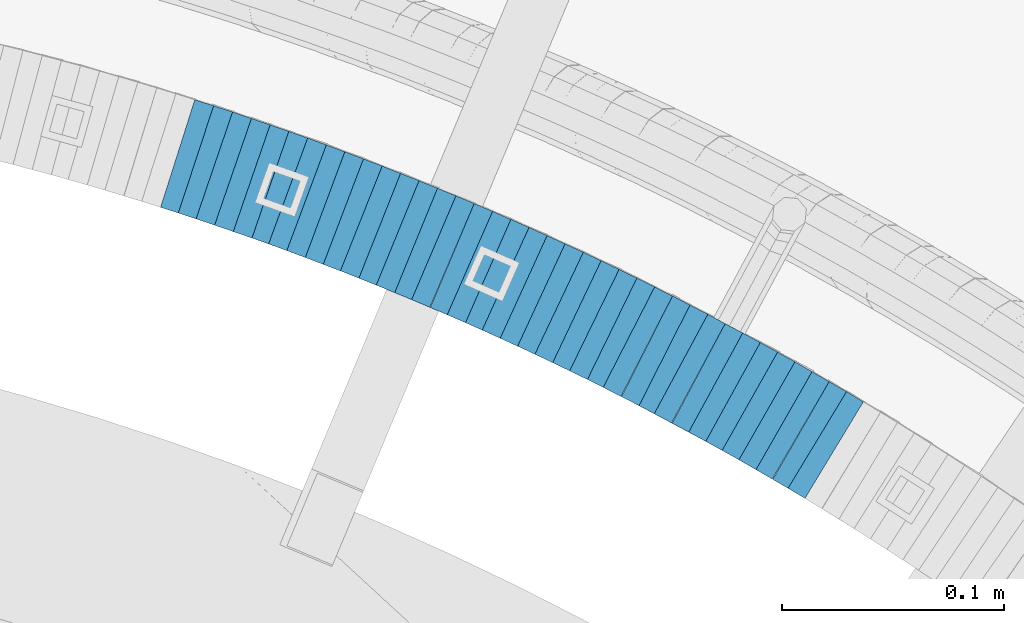
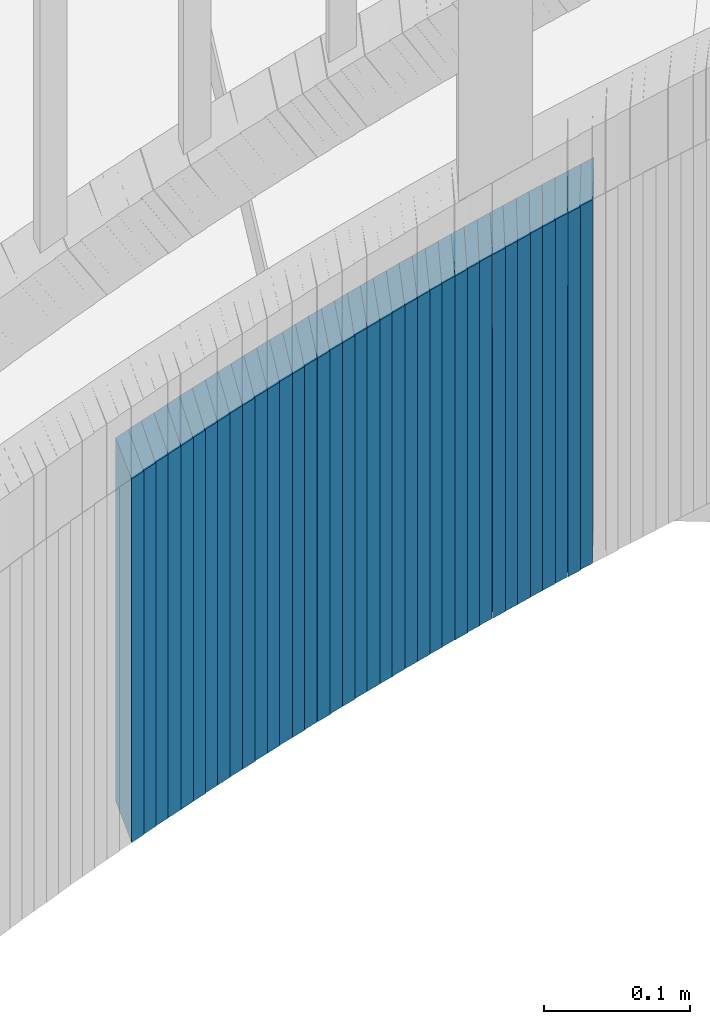
# One storey, part 900 of 975: 37 plates.
"""IFC2X3 building model written with IfcOpenShell, lengths in millimetres."""

from ifc_helpers import new_model, si_unit, frame, origin_with_axes, place, context, subcontext, project, spatial, faceted_brep, material, type_object, element, save


model = new_model("IFC2X3")

# Units and contexts
model_context = context("Model", 3, precision=1e-05, world=origin_with_axes())
body_context = subcontext(model_context, "Body", "Model", "MODEL_VIEW")
ifc_project = project(units=[si_unit("LENGTHUNIT", "METRE", prefix="MILLI"), si_unit("AREAUNIT", "SQUARE_METRE"), si_unit("VOLUMEUNIT", "CUBIC_METRE"), si_unit("MASSUNIT", "GRAM", prefix="KILO"), si_unit("TIMEUNIT", "SECOND"), si_unit("PLANEANGLEUNIT", "RADIAN"), si_unit("SOLIDANGLEUNIT", "STERADIAN"), si_unit("THERMODYNAMICTEMPERATUREUNIT", "DEGREE_CELSIUS"), si_unit("LUMINOUSINTENSITYUNIT", "LUMEN")], contexts=[model_context])

# Site, building, storey
site_placement = place(None, origin_with_axes())
site = spatial("IfcSite", under=ifc_project, at=site_placement, CompositionType="ELEMENT")
building_placement = place(site_placement, origin_with_axes())
building = spatial("IfcBuilding", under=site, at=building_placement, Name="Undefined", CompositionType="ELEMENT")
storey_placement = place(building_placement, origin_with_axes())
storey = spatial("IfcBuildingStorey", under=building, at=storey_placement, Name="Undefined", CompositionType="ELEMENT", Elevation=0.0)

# Plates
ifc_material = material(Name="STEEL/A36")
plate_type = type_object("IfcPlateType", PredefinedType="NOTDEFINED")
plate_1_placement = place(storey_placement, frame((35445.7233740087, 4606.22785102117, 1554.3000000007), z_axis=(0.855500079109598, -0.517802679254822, 1.05275375972269e-10), x_axis=(0.0, 0.0, -1.0)))
element("IfcPlate", 1, at=plate_1_placement, inside=storey, type_object=plate_type, material=ifc_material, Name="WALL", context=body_context, shape_type="Brep", body=[
    faceted_brep([(0.0, -25.3999999999724, -1.81898940354586e-11), (-5.69999980926514, -25.4000000000669, 8.8814411163039), (-5.69999980926514, 25.400000000096, 8.88144111637848), (0.0, 25.3999999999869, 1.45519152283669e-11), (299.100006103516, -25.4000000000669, 8.8814411163039), (299.100006103516, 25.400000000096, 8.88144111637848), (304.799987792969, -25.3999999999724, -1.81898940354586e-11), (304.799987792969, 25.3999999999869, 1.45519152283669e-11)], [[[0, 1, 2, 3]], [[1, 4, 5, 2]], [[4, 6, 7, 5]], [[6, 0, 3, 7]], [[5, 7, 3, 2]], [[6, 4, 1, 0]]]),
])
plate_2_placement = place(storey_placement, frame((35438.3826117312, 4610.45643915297, 1548.5000000007), z_axis=(0.866185585981234, -0.499722453606346, 3.44320142176002e-10), x_axis=(0.0, 0.0, -1.0)))
element("IfcPlate", 2, at=plate_2_placement, inside=storey, type_object=plate_type, material=ifc_material, Name="WALL", context=body_context, shape_type="Brep", body=[
    faceted_brep([(0.0, -25.3999999999724, -1.81898940354586e-11), (-5.80000019073486, -25.3999999999578, 8.99610996247975), (-5.80000019073486, 25.3999999999796, 8.99610996245065), (0.0, 25.3999999999869, 1.45519152283669e-11), (299.0, -25.3999999999578, 8.99610996247975), (299.0, 25.3999999999796, 8.99610996245065), (304.799987792969, -25.3999999999724, -1.81898940354586e-11), (304.799987792969, 25.3999999999869, 1.45519152283669e-11)], [[[0, 1, 2, 3]], [[1, 4, 5, 2]], [[4, 6, 7, 5]], [[6, 0, 3, 7]], [[5, 7, 3, 2]], [[6, 4, 1, 0]]]),
])
plate_3_placement = place(storey_placement, frame((35430.5595343687, 4615.02790564917, 1542.80000000069), z_axis=(0.863371944049593, -0.504568019426546, 2.19373305299087e-10), x_axis=(0.0, 0.0, -1.0)))
element("IfcPlate", 3, at=plate_3_placement, inside=storey, type_object=plate_type, material=ifc_material, Name="WALL", context=body_context, shape_type="Brep", body=[
    faceted_brep([(0.0, -25.3999999999724, -1.81898940354586e-11), (-5.69999980926514, -25.3999999999724, 8.91964149478372), (-5.69999980926514, 25.400000000016, 8.9196414947528), (0.0, 25.3999999999869, 1.45519152283669e-11), (299.100006103516, -25.3999999999724, 8.91964149478372), (299.100006103516, 25.400000000016, 8.9196414947528), (304.799987792969, -25.3999999999724, -1.81898940354586e-11), (304.799987792969, 25.3999999999869, 1.45519152283669e-11)], [[[0, 1, 2, 3]], [[1, 4, 5, 2]], [[4, 6, 7, 5]], [[6, 0, 3, 7]], [[5, 7, 3, 2]], [[6, 4, 1, 0]]]),
])
plate_4_placement = place(storey_placement, frame((35423.0736330301, 4619.30417721957, 1537.10000000069), z_axis=(0.868243142247536, -0.49613893814145, 0.0), x_axis=(0.0, 0.0, -1.0)))
element("IfcPlate", 4, at=plate_4_placement, inside=storey, type_object=plate_type, material=ifc_material, Name="WALL", context=body_context, shape_type="Brep", body=[
    faceted_brep([(0.0, -25.3999999999724, -1.81898940354586e-11), (-5.69999980926514, -25.4000000000378, 8.86848354337781), (-5.69999980926514, 25.4000000000451, 8.86848354342146), (0.0, 25.3999999999869, 1.45519152283669e-11), (299.100006103516, -25.4000000000378, 8.86848354337781), (299.100006103516, 25.4000000000451, 8.86848354342146), (304.799987792969, -25.3999999999724, -1.81898940354586e-11), (304.799987792969, 25.3999999999869, 1.45519152283669e-11)], [[[0, 1, 2, 3]], [[1, 4, 5, 2]], [[4, 6, 7, 5]], [[6, 0, 3, 7]], [[5, 7, 3, 2]], [[6, 4, 1, 0]]]),
])
plate_5_placement = place(storey_placement, frame((35415.3960039102, 4623.63469995071, 1531.40000000068), z_axis=(0.870978467909721, -0.491321186636232, -1.73427451954922e-10), x_axis=(0.0, 0.0, -1.0)))
element("IfcPlate", 5, at=plate_5_placement, inside=storey, type_object=plate_type, material=ifc_material, Name="WALL", context=body_context, shape_type="Brep", body=[
    faceted_brep([(0.0, -25.3999999999724, -1.81898940354586e-11), (-5.69999980926514, -25.4000000000087, 8.9643735885511), (-5.69999980926514, 25.4000000000669, 8.96437358860567), (0.0, 25.3999999999869, 1.45519152283669e-11), (299.100006103516, -25.4000000000087, 8.9643735885511), (299.100006103516, 25.4000000000669, 8.96437358860567), (304.799987792969, -25.3999999999724, -1.81898940354586e-11), (304.799987792969, 25.3999999999869, 1.45519152283669e-11)], [[[0, 1, 2, 3]], [[1, 4, 5, 2]], [[4, 6, 7, 5]], [[6, 0, 3, 7]], [[5, 7, 3, 2]], [[6, 4, 1, 0]]]),
])
plate_6_placement = place(storey_placement, frame((35407.8129371245, 4627.81372175488, 1525.60000000066), z_axis=(0.875741388860291, -0.482780508965563, 2.42835085373372e-11), x_axis=(0.0, 0.0, -1.0)))
element("IfcPlate", 6, at=plate_6_placement, inside=storey, type_object=plate_type, material=ifc_material, Name="WALL", context=body_context, shape_type="Brep", body=[
    faceted_brep([(0.0, -25.3999999999724, -1.81898940354586e-11), (-5.80000019073486, -25.399999999976, 8.91066741944087), (-5.80000019073486, 25.4000000000051, 8.91066741945178), (0.0, 25.3999999999869, 1.45519152283669e-11), (299.0, -25.399999999976, 8.91066741944087), (299.0, 25.4000000000051, 8.91066741945178), (304.799987792969, -25.3999999999724, -1.81898940354586e-11), (304.799987792969, 25.3999999999869, 1.45519152283669e-11)], [[[0, 1, 2, 3]], [[1, 4, 5, 2]], [[4, 6, 7, 5]], [[6, 0, 3, 7]], [[5, 7, 3, 2]], [[6, 4, 1, 0]]]),
])
plate_7_placement = place(storey_placement, frame((35400.0325084612, 4632.04822203603, 1519.90000000066), z_axis=(0.878320117971443, -0.478072975984453, 0.0), x_axis=(0.0, 0.0, -1.0)))
element("IfcPlate", 7, at=plate_7_placement, inside=storey, type_object=plate_type, material=ifc_material, Name="WALL", context=body_context, shape_type="Brep", body=[
    faceted_brep([(0.0, -25.3999999999724, -1.81898940354586e-11), (-5.69999980926514, -25.3999999999724, 8.9872131347729), (-5.69999980926514, 25.3999999999833, 8.98721313475835), (0.0, 25.3999999999869, 1.45519152283669e-11), (299.100006103516, -25.3999999999724, 8.9872131347729), (299.100006103516, 25.3999999999833, 8.98721313475835), (304.799987792969, -25.3999999999724, -1.81898940354586e-11), (304.799987792969, 25.3999999999869, 1.45519152283669e-11)], [[[0, 1, 2, 3]], [[1, 4, 5, 2]], [[4, 6, 7, 5]], [[6, 0, 3, 7]], [[5, 7, 3, 2]], [[6, 4, 1, 0]]]),
])
plate_8_placement = place(storey_placement, frame((35392.3521009664, 4636.13009049923, 1514.20000000066), z_axis=(0.882970965834168, -0.469427601972739, 3.48595676769037e-11), x_axis=(0.0, 0.0, -1.0)))
element("IfcPlate", 8, at=plate_8_placement, inside=storey, type_object=plate_type, material=ifc_material, Name="WALL", context=body_context, shape_type="Brep", body=[
    faceted_brep([(0.0, -25.3999999999724, -1.81898940354586e-11), (-5.69999980926514, -25.4000000000451, 8.94986057279493), (-5.69999980926514, 25.3999999999942, 8.94986057280948), (0.0, 25.3999999999869, 1.45519152283669e-11), (299.100006103516, -25.4000000000451, 8.94986057279493), (299.100006103516, 25.3999999999942, 8.94986057280948), (304.799987792969, -25.3999999999724, -1.81898940354586e-11), (304.799987792969, 25.3999999999869, 1.45519152283669e-11)], [[[0, 1, 2, 3]], [[1, 4, 5, 2]], [[4, 6, 7, 5]], [[6, 0, 3, 7]], [[5, 7, 3, 2]], [[6, 4, 1, 0]]]),
])
plate_9_placement = place(storey_placement, frame((35384.4334265492, 4640.39358709318, 1508.40000000065), z_axis=(0.880471099954286, -0.474099822975383, 0.0), x_axis=(0.0, 0.0, -1.0)))
element("IfcPlate", 9, at=plate_9_placement, inside=storey, type_object=plate_type, material=ifc_material, Name="WALL", context=body_context, shape_type="Brep", body=[
    faceted_brep([(0.0, -25.3999999999724, -1.81898940354586e-11), (-5.80000019073486, -25.3999999999905, 8.8617153167761), (-5.80000019073486, 25.4000000000524, 8.86171531681975), (0.0, 25.3999999999869, 1.45519152283669e-11), (299.0, -25.3999999999905, 8.8617153167761), (299.0, 25.4000000000524, 8.86171531681975), (304.799987792969, -25.3999999999724, -1.81898940354586e-11), (304.799987792969, 25.3999999999869, 1.45519152283669e-11)], [[[0, 1, 2, 3]], [[1, 4, 5, 2]], [[4, 6, 7, 5]], [[6, 0, 3, 7]], [[5, 7, 3, 2]], [[6, 4, 1, 0]]]),
])
plate_10_placement = place(storey_placement, frame((35376.668781017, 4644.46844629938, 1502.70000000065), z_axis=(0.8853979028468, -0.464833898973051, 2.98718987323809e-11), x_axis=(0.0, 0.0, -1.0)))
element("IfcPlate", 10, at=plate_10_placement, inside=storey, type_object=plate_type, material=ifc_material, Name="WALL", context=body_context, shape_type="Brep", body=[
    faceted_brep([(0.0, -25.3999999999724, -1.81898940354586e-11), (-5.69999980926514, -25.3999999999614, 9.03548526772647), (-5.69999980926514, 25.3999999999869, 9.03548526759187), (0.0, 25.3999999999869, 1.45519152283669e-11), (299.100006103516, -25.3999999999614, 9.03548526772647), (299.100006103516, 25.3999999999869, 9.03548526759187), (304.799987792969, -25.3999999999724, -1.81898940354586e-11), (304.799987792969, 25.3999999999869, 1.45519152283669e-11)], [[[0, 1, 2, 3]], [[1, 4, 5, 2]], [[4, 6, 7, 5]], [[6, 0, 3, 7]], [[5, 7, 3, 2]], [[6, 4, 1, 0]]]),
])
plate_11_placement = place(storey_placement, frame((35369.1017434079, 4648.29676121252, 1497.00000000065), z_axis=(0.892157158245305, -0.451725143191812, 3.88258740713355e-11), x_axis=(0.0, 0.0, -1.0)))
element("IfcPlate", 11, at=plate_11_placement, inside=storey, type_object=plate_type, material=ifc_material, Name="WALL", context=body_context, shape_type="Brep", body=[
    faceted_brep([(0.0, -25.3999999999724, -1.81898940354586e-11), (-5.69999980926514, -25.4000000000669, 8.85494232174278), (-5.69999980926514, 25.4000000000742, 8.85494232181918), (0.0, 25.3999999999869, 1.45519152283669e-11), (299.100006103516, -25.4000000000669, 8.85494232174278), (299.100006103516, 25.4000000000742, 8.85494232181918), (304.799987792969, -25.3999999999724, -1.81898940354586e-11), (304.799987792969, 25.3999999999869, 1.45519152283669e-11)], [[[0, 1, 2, 3]], [[1, 4, 5, 2]], [[4, 6, 7, 5]], [[6, 0, 3, 7]], [[5, 7, 3, 2]], [[6, 4, 1, 0]]]),
])
plate_12_placement = place(storey_placement, frame((35360.990855953, 4652.45324846724, 1491.20000000064), z_axis=(0.88993325058996, -0.456090790845844, 3.15944816975389e-11), x_axis=(0.0, 0.0, -1.0)))
element("IfcPlate", 12, at=plate_12_placement, inside=storey, type_object=plate_type, material=ifc_material, Name="WALL", context=body_context, shape_type="Brep", body=[
    faceted_brep([(0.0, -25.3999999999724, -1.81898940354586e-11), (-5.80000019073486, -25.3999999999796, 8.98721313478018), (-5.80000019073486, 25.399999999936, 8.98721313473106), (0.0, 25.3999999999869, 1.45519152283669e-11), (299.0, -25.3999999999796, 8.98721313478018), (299.0, 25.399999999936, 8.98721313473106), (304.799987792969, -25.3999999999724, -1.81898940354586e-11), (304.799987792969, 25.3999999999869, 1.45519152283669e-11)], [[[0, 1, 2, 3]], [[1, 4, 5, 2]], [[4, 6, 7, 5]], [[6, 0, 3, 7]], [[5, 7, 3, 2]], [[6, 4, 1, 0]]]),
])
plate_13_placement = place(storey_placement, frame((35353.2163367046, 4656.33910238603, 1485.50000000063), z_axis=(0.894427190945564, -0.447213595608663, -1.9893241187674e-10), x_axis=(0.0, 0.0, -1.0)))
element("IfcPlate", 13, at=plate_13_placement, inside=storey, type_object=plate_type, material=ifc_material, Name="WALL", context=body_context, shape_type="Brep", body=[
    faceted_brep([(0.0, -25.3999999999724, -1.81898940354586e-11), (-5.69999980926514, -25.4000000000415, 8.93756103511259), (-5.69999980926514, 25.4000000000815, 8.93756103522537), (0.0, 25.3999999999869, 1.45519152283669e-11), (299.100006103516, -25.4000000000415, 8.93756103511259), (299.100006103516, 25.4000000000815, 8.93756103522537), (304.799987792969, -25.3999999999724, -1.81898940354586e-11), (304.799987792969, 25.3999999999869, 1.45519152283669e-11)], [[[0, 1, 2, 3]], [[1, 4, 5, 2]], [[4, 6, 7, 5]], [[6, 0, 3, 7]], [[5, 7, 3, 2]], [[6, 4, 1, 0]]]),
])
plate_14_placement = place(storey_placement, frame((35345.4452249515, 4660.12609235878, 1479.80000000063), z_axis=(0.898876404474688, -0.43820224723141, 0.0), x_axis=(0.0, 0.0, -1.0)))
element("IfcPlate", 14, at=plate_14_placement, inside=storey, type_object=plate_type, material=ifc_material, Name="WALL", context=body_context, shape_type="Brep", body=[
    faceted_brep([(0.0, -25.3999999999724, -1.81898940354586e-11), (-5.69999980926514, -25.3999999999724, 8.90224647524519), (-5.69999980926514, 25.3999999999542, 8.90224647519426), (0.0, 25.3999999999869, 1.45519152283669e-11), (299.100006103516, -25.3999999999724, 8.90224647524519), (299.100006103516, 25.3999999999542, 8.90224647519426), (304.799987792969, -25.3999999999724, -1.81898940354586e-11), (304.799987792969, 25.3999999999869, 1.45519152283669e-11)], [[[0, 1, 2, 3]], [[1, 4, 5, 2]], [[4, 6, 7, 5]], [[6, 0, 3, 7]], [[5, 7, 3, 2]], [[6, 4, 1, 0]]]),
])
plate_15_placement = place(storey_placement, frame((35337.4566453103, 4663.97211062152, 1474.10000000063), z_axis=(0.901001669715669, -0.433815618863102, 0.0), x_axis=(0.0, 0.0, -1.0)))
element("IfcPlate", 15, at=plate_15_placement, inside=storey, type_object=plate_type, material=ifc_material, Name="WALL", context=body_context, shape_type="Brep", body=[
    faceted_brep([(0.0, -25.3999999999724, -1.81898940354586e-11), (-5.69999980926514, -25.3999999999724, 8.9872131347729), (-5.69999980926514, 25.3999999999833, 8.98721313475835), (0.0, 25.3999999999869, 1.45519152283669e-11), (299.100006103516, -25.3999999999724, 8.9872131347729), (299.100006103516, 25.3999999999833, 8.98721313475835), (304.799987792969, -25.3999999999724, -1.81898940354586e-11), (304.799987792969, 25.3999999999869, 1.45519152283669e-11)], [[[0, 1, 2, 3]], [[1, 4, 5, 2]], [[4, 6, 7, 5]], [[6, 0, 3, 7]], [[5, 7, 3, 2]], [[6, 4, 1, 0]]]),
])
plate_16_placement = place(storey_placement, frame((35329.5775189319, 4667.71430442811, 1468.30000000063), z_axis=(0.90327750431061, -0.429056814660246, -2.83282133750618e-10), x_axis=(0.0, 0.0, -1.0)))
element("IfcPlate", 16, at=plate_16_placement, inside=storey, type_object=plate_type, material=ifc_material, Name="WALL", context=body_context, shape_type="Brep", body=[
    faceted_brep([(0.0, -25.3999999999724, -1.81898940354586e-11), (-5.80000019073486, -25.3999999999905, 8.8617153167761), (-5.80000019073486, 25.4000000000524, 8.86171531681975), (0.0, 25.3999999999869, 1.45519152283669e-11), (299.0, -25.3999999999905, 8.8617153167761), (299.0, 25.4000000000524, 8.86171531681975), (304.799987792969, -25.3999999999724, -1.81898940354586e-11), (304.799987792969, 25.3999999999869, 1.45519152283669e-11)], [[[0, 1, 2, 3]], [[1, 4, 5, 2]], [[4, 6, 7, 5]], [[6, 0, 3, 7]], [[5, 7, 3, 2]], [[6, 4, 1, 0]]]),
])
plate_17_placement = place(storey_placement, frame((35321.5958523113, 4671.41186362731, 1462.60000000063), z_axis=(0.90731060653378, -0.420461012783949, 0.0), x_axis=(0.0, 0.0, -1.0)))
element("IfcPlate", 17, at=plate_17_placement, inside=storey, type_object=plate_type, material=ifc_material, Name="WALL", context=body_context, shape_type="Brep", body=[
    faceted_brep([(0.0, -25.3999999999724, -1.81898940354586e-11), (-5.69999980926514, -25.3999999999614, 9.03548526772647), (-5.69999980926514, 25.3999999999869, 9.03548526759187), (0.0, 25.3999999999869, 1.45519152283669e-11), (299.100006103516, -25.3999999999614, 9.03548526772647), (299.100006103516, 25.3999999999869, 9.03548526759187), (304.799987792969, -25.3999999999724, -1.81898940354586e-11), (304.799987792969, 25.3999999999869, 1.45519152283669e-11)], [[[0, 1, 2, 3]], [[1, 4, 5, 2]], [[4, 6, 7, 5]], [[6, 0, 3, 7]], [[5, 7, 3, 2]], [[6, 4, 1, 0]]]),
])
plate_18_placement = place(storey_placement, frame((35313.6220053437, 4675.0538208408, 1456.90000000062), z_axis=(0.909595755713219, -0.415494357589244, -1.62878222909057e-10), x_axis=(0.0, 0.0, -1.0)))
element("IfcPlate", 18, at=plate_18_placement, inside=storey, type_object=plate_type, material=ifc_material, Name="WALL", context=body_context, shape_type="Brep", body=[
    faceted_brep([(0.0, -25.3999999999724, -1.81898940354586e-11), (-5.69999980926514, -25.400000000096, 8.9140338897214), (-5.69999980926514, 25.4000000000524, 8.91403388979779), (0.0, 25.3999999999869, 1.45519152283669e-11), (299.100006103516, -25.400000000096, 8.9140338897214), (299.100006103516, 25.4000000000524, 8.91403388979779), (304.799987792969, -25.3999999999724, -1.81898940354586e-11), (304.799987792969, 25.3999999999869, 1.45519152283669e-11)], [[[0, 1, 2, 3]], [[1, 4, 5, 2]], [[4, 6, 7, 5]], [[6, 0, 3, 7]], [[5, 7, 3, 2]], [[6, 4, 1, 0]]]),
])
plate_19_placement = place(storey_placement, frame((35305.52200534, 4678.75382084077, 1451.10000000062), z_axis=(0.909595755713219, -0.415494357589244, -1.62878222909057e-10), x_axis=(0.0, 0.0, -1.0)))
element("IfcPlate", 19, at=plate_19_placement, inside=storey, type_object=plate_type, material=ifc_material, Name="WALL", context=body_context, shape_type="Brep", body=[
    faceted_brep([(0.0, -25.3999999999724, -1.81898940354586e-11), (-5.80000019073486, -25.399999999976, 8.91066741944087), (-5.80000019073486, 25.4000000000051, 8.91066741945178), (0.0, 25.3999999999869, 1.45519152283669e-11), (299.0, -25.399999999976, 8.91066741944087), (299.0, 25.4000000000051, 8.91066741945178), (304.799987792969, -25.3999999999724, -1.81898940354586e-11), (304.799987792969, 25.3999999999869, 1.45519152283669e-11)], [[[0, 1, 2, 3]], [[1, 4, 5, 2]], [[4, 6, 7, 5]], [[6, 0, 3, 7]], [[5, 7, 3, 2]], [[6, 4, 1, 0]]]),
])
plate_20_placement = place(storey_placement, frame((35297.6650144504, 4682.20019466685, 1445.40000000062), z_axis=(0.91564403017333, -0.401990062076094, 0.0), x_axis=(0.0, 0.0, -1.0)))
element("IfcPlate", 20, at=plate_20_placement, inside=storey, type_object=plate_type, material=ifc_material, Name="WALL", context=body_context, shape_type="Brep", body=[
    faceted_brep([(0.0, -25.3999999999724, -1.81898940354586e-11), (-5.69999980926514, -25.4000000000087, 8.9643735885511), (-5.69999980926514, 25.4000000000669, 8.96437358860567), (0.0, 25.3999999999869, 1.45519152283669e-11), (299.100006103516, -25.4000000000087, 8.9643735885511), (299.100006103516, 25.4000000000669, 8.96437358860567), (304.799987792969, -25.3999999999724, -1.81898940354586e-11), (304.799987792969, 25.3999999999869, 1.45519152283669e-11)], [[[0, 1, 2, 3]], [[1, 4, 5, 2]], [[4, 6, 7, 5]], [[6, 0, 3, 7]], [[5, 7, 3, 2]], [[6, 4, 1, 0]]]),
])
plate_21_placement = place(storey_placement, frame((35289.4650144489, 4685.80019466682, 1439.60000000061), z_axis=(0.91564403017333, -0.401990062076094, 0.0), x_axis=(0.0, 0.0, -1.0)))
element("IfcPlate", 21, at=plate_21_placement, inside=storey, type_object=plate_type, material=ifc_material, Name="WALL", context=body_context, shape_type="Brep", body=[
    faceted_brep([(0.0, -25.3999999999724, -1.81898940354586e-11), (-5.80000019073486, -25.3999999999396, 8.9627008438656), (-5.80000019073486, 25.3999999999178, 8.96270084374191), (0.0, 25.3999999999869, 1.45519152283669e-11), (299.0, -25.3999999999396, 8.9627008438656), (299.0, 25.3999999999178, 8.96270084374191), (304.799987792969, -25.3999999999724, -1.81898940354586e-11), (304.799987792969, 25.3999999999869, 1.45519152283669e-11)], [[[0, 1, 2, 3]], [[1, 4, 5, 2]], [[4, 6, 7, 5]], [[6, 0, 3, 7]], [[5, 7, 3, 2]], [[6, 4, 1, 0]]]),
])
plate_22_placement = place(storey_placement, frame((35281.5063095508, 4689.15332573016, 1433.90000000062), z_axis=(0.921426271776065, -0.388553246905571, 0.0), x_axis=(0.0, 0.0, -1.0)))
element("IfcPlate", 22, at=plate_22_placement, inside=storey, type_object=plate_type, material=ifc_material, Name="WALL", context=body_context, shape_type="Brep", body=[
    faceted_brep([(0.0, -25.3999999999724, -1.81898940354586e-11), (-5.69999980926514, -25.4000000000087, 9.01387786864507), (-5.69999980926514, 25.4000000000124, 9.0138778686669), (0.0, 25.3999999999869, 1.45519152283669e-11), (299.100006103516, -25.4000000000087, 9.01387786864507), (299.100006103516, 25.4000000000124, 9.0138778686669), (304.799987792969, -25.3999999999724, -1.81898940354586e-11), (304.799987792969, 25.3999999999869, 1.45519152283669e-11)], [[[0, 1, 2, 3]], [[1, 4, 5, 2]], [[4, 6, 7, 5]], [[6, 0, 3, 7]], [[5, 7, 3, 2]], [[6, 4, 1, 0]]]),
])
plate_23_placement = place(storey_placement, frame((35273.2044059858, 4692.69655888807, 1428.10000000061), z_axis=(0.919724178958897, -0.392565197946001, -2.1436790120788e-11), x_axis=(0.0, 0.0, -1.0)))
element("IfcPlate", 23, at=plate_23_placement, inside=storey, type_object=plate_type, material=ifc_material, Name="WALL", context=body_context, shape_type="Brep", body=[
    faceted_brep([(0.0, -25.3999999999724, -1.81898940354586e-11), (-5.80000019073486, -25.3999999999724, 8.9196414947728), (-5.80000019073486, 25.4000000000342, 8.91964149478736), (0.0, 25.3999999999869, 1.45519152283669e-11), (299.0, -25.3999999999724, 8.9196414947728), (299.0, 25.4000000000342, 8.91964149478736), (304.799987792969, -25.3999999999724, -1.81898940354586e-11), (304.799987792969, 25.3999999999869, 1.45519152283669e-11)], [[[0, 1, 2, 3]], [[1, 4, 5, 2]], [[4, 6, 7, 5]], [[6, 0, 3, 7]], [[5, 7, 3, 2]], [[6, 4, 1, 0]]]),
])
for number, where, z_axis, x_axis, name in (
    (24, (35265.2472621116, 4695.95317384506, 1422.4000000006), (0.925369259230161, -0.379066925584154, 2.88076535071014e-10), (0.0, 0.0, -1.0), "WALL"),
    (25, (35256.9472621081, 4699.35317384519, 1416.7000000006), (0.925369259230161, -0.379066925584154, 2.88076535071014e-10), (0.0, 0.0, -1.0), "WALL"),
):
    element("IfcPlate", number, at=place(storey_placement, frame(where, z_axis=z_axis, x_axis=x_axis)), inside=storey, type_object=plate_type, material=ifc_material, Name=name, context=body_context, shape_type="Brep", body=[
        faceted_brep([(0.0, -25.3999999999724, -1.81898940354586e-11), (-5.69999980926514, -25.4000000000669, 8.96939277644015), (-5.69999980926514, 25.4000000000524, 8.96939277652928), (0.0, 25.3999999999869, 1.45519152283669e-11), (299.100006103516, -25.4000000000669, 8.96939277644015), (299.100006103516, 25.4000000000524, 8.96939277652928), (304.799987792969, -25.3999999999724, -1.81898940354586e-11), (304.799987792969, 25.3999999999869, 1.45519152283669e-11)], [[[0, 1, 2, 3]], [[1, 4, 5, 2]], [[4, 6, 7, 5]], [[6, 0, 3, 7]], [[5, 7, 3, 2]], [[6, 4, 1, 0]]]),
    ])
plate_24_placement = place(storey_placement, frame((35248.8912888578, 4702.55468419485, 1410.9000000006), z_axis=(0.929246804674932, -0.36945957289185, 1.25100996228866e-11), x_axis=(0.0, 0.0, -1.0)))
element("IfcPlate", 26, at=plate_24_placement, inside=storey, type_object=plate_type, material=ifc_material, Name="WALL", context=body_context, shape_type="Brep", body=[
    faceted_brep([(0.0, -25.3999999999724, -1.81898940354586e-11), (-5.80000019073486, -25.399999999976, 8.9274854660398), (-5.80000019073486, 25.4000000000269, 8.92748546601433), (0.0, 25.3999999999869, 1.45519152283669e-11), (299.0, -25.399999999976, 8.9274854660398), (299.0, 25.4000000000269, 8.92748546601433), (304.799987792969, -25.3999999999724, -1.81898940354586e-11), (304.799987792969, 25.3999999999869, 1.45519152283669e-11)], [[[0, 1, 2, 3]], [[1, 4, 5, 2]], [[4, 6, 7, 5]], [[6, 0, 3, 7]], [[5, 7, 3, 2]], [[6, 4, 1, 0]]]),
])
plate_25_placement = place(storey_placement, frame((35240.5912888593, 4705.85468419462, 1405.20000000061), z_axis=(0.929246804674932, -0.36945957289185, 1.25100996228866e-11), x_axis=(0.0, 0.0, -1.0)))
element("IfcPlate", 27, at=plate_25_placement, inside=storey, type_object=plate_type, material=ifc_material, Name="WALL", context=body_context, shape_type="Brep", body=[
    faceted_brep([(0.0, -25.3999999999724, -1.81898940354586e-11), (-5.69999980926514, -25.3999999999141, 8.92748546604707), (-5.69999980926514, 25.3999999999505, 8.92748546598159), (0.0, 25.3999999999869, 1.45519152283669e-11), (299.100006103516, -25.3999999999141, 8.92748546604707), (299.100006103516, 25.3999999999505, 8.92748546598159), (304.799987792969, -25.3999999999724, -1.81898940354586e-11), (304.799987792969, 25.3999999999869, 1.45519152283669e-11)], [[[0, 1, 2, 3]], [[1, 4, 5, 2]], [[4, 6, 7, 5]], [[6, 0, 3, 7]], [[5, 7, 3, 2]], [[6, 4, 1, 0]]]),
])
plate_26_placement = place(storey_placement, frame((35232.5332806787, 4708.92156456928, 1399.40000000061), z_axis=(0.934487734986244, -0.355995327441637, -3.27765519614332e-10), x_axis=(0.0, 0.0, -1.0)))
element("IfcPlate", 28, at=plate_26_placement, inside=storey, type_object=plate_type, material=ifc_material, Name="WALL", context=body_context, shape_type="Brep", body=[
    faceted_brep([(0.0, -25.3999999999724, -1.81898940354586e-11), (-5.80000019073486, -25.3999999999796, 8.98721313478018), (-5.80000019073486, 25.399999999936, 8.98721313473106), (0.0, 25.3999999999869, 1.45519152283669e-11), (299.0, -25.3999999999796, 8.98721313478018), (299.0, 25.399999999936, 8.98721313473106), (304.799987792969, -25.3999999999724, -1.81898940354586e-11), (304.799987792969, 25.3999999999869, 1.45519152283669e-11)], [[[0, 1, 2, 3]], [[1, 4, 5, 2]], [[4, 6, 7, 5]], [[6, 0, 3, 7]], [[5, 7, 3, 2]], [[6, 4, 1, 0]]]),
])
plate_27_placement = place(storey_placement, frame((35224.1332806765, 4712.12156456904, 1393.70000000061), z_axis=(0.934487734986244, -0.355995327441637, -3.27765519614332e-10), x_axis=(0.0, 0.0, -1.0)))
element("IfcPlate", 29, at=plate_27_placement, inside=storey, type_object=plate_type, material=ifc_material, Name="WALL", context=body_context, shape_type="Brep", body=[
    faceted_brep([(0.0, -25.3999999999724, -1.81898940354586e-11), (-5.69999980926514, -25.3999999999724, 8.9872131347729), (-5.69999980926514, 25.3999999999833, 8.98721313475835), (0.0, 25.3999999999869, 1.45519152283669e-11), (299.100006103516, -25.3999999999724, 8.9872131347729), (299.100006103516, 25.3999999999833, 8.98721313475835), (304.799987792969, -25.3999999999724, -1.81898940354586e-11), (304.799987792969, 25.3999999999869, 1.45519152283669e-11)], [[[0, 1, 2, 3]], [[1, 4, 5, 2]], [[4, 6, 7, 5]], [[6, 0, 3, 7]], [[5, 7, 3, 2]], [[6, 4, 1, 0]]]),
])
plate_28_placement = place(storey_placement, frame((35215.9884514681, 4715.16303126436, 1387.90000000061), z_axis=(0.936792195612456, -0.349886241855255, 0.0), x_axis=(0.0, 0.0, -1.0)))
element("IfcPlate", 30, at=plate_28_placement, inside=storey, type_object=plate_type, material=ifc_material, Name="WALL", context=body_context, shape_type="Brep", body=[
    faceted_brep([(0.0, -25.3999999999724, -1.81898940354586e-11), (-5.80000019073486, -25.3999999999905, 8.8617153167761), (-5.80000019073486, 25.4000000000524, 8.86171531681975), (0.0, 25.3999999999869, 1.45519152283669e-11), (299.0, -25.3999999999905, 8.8617153167761), (299.0, 25.4000000000524, 8.86171531681975), (304.799987792969, -25.3999999999724, -1.81898940354586e-11), (304.799987792969, 25.3999999999869, 1.45519152283669e-11)], [[[0, 1, 2, 3]], [[1, 4, 5, 2]], [[4, 6, 7, 5]], [[6, 0, 3, 7]], [[5, 7, 3, 2]], [[6, 4, 1, 0]]]),
])
plate_29_placement = place(storey_placement, frame((35207.681501122, 4718.22848479777, 1382.2000000006), z_axis=(0.938152292619596, -0.346222870204433, 2.09550762519939e-10), x_axis=(0.0, 0.0, -1.0)))
element("IfcPlate", 31, at=plate_29_placement, inside=storey, type_object=plate_type, material=ifc_material, Name="WALL", context=body_context, shape_type="Brep", body=[
    faceted_brep([(0.0, -25.3999999999724, -1.81898940354586e-11), (-5.69999980926514, -25.4000000000451, 8.94986057279493), (-5.69999980926514, 25.3999999999942, 8.94986057280948), (0.0, 25.3999999999869, 1.45519152283669e-11), (299.100006103516, -25.4000000000451, 8.94986057279493), (299.100006103516, 25.3999999999942, 8.94986057280948), (304.799987792969, -25.3999999999724, -1.81898940354586e-11), (304.799987792969, 25.3999999999869, 1.45519152283669e-11)], [[[0, 1, 2, 3]], [[1, 4, 5, 2]], [[4, 6, 7, 5]], [[6, 0, 3, 7]], [[5, 7, 3, 2]], [[6, 4, 1, 0]]]),
])
plate_30_placement = place(storey_placement, frame((35199.5219310265, 4721.10559856145, 1376.5000000006), z_axis=(0.9429903335255, -0.332820117897741, 3.95689312426839e-11), x_axis=(0.0, 0.0, -1.0)))
element("IfcPlate", 32, at=plate_30_placement, inside=storey, type_object=plate_type, material=ifc_material, Name="WALL", context=body_context, shape_type="Brep", body=[
    faceted_brep([(0.0, -25.3999999999724, -1.81898940354586e-11), (-5.69999980926514, -25.4000000000087, 9.01387786864507), (-5.69999980926514, 25.4000000000124, 9.0138778686669), (0.0, 25.3999999999869, 1.45519152283669e-11), (299.100006103516, -25.4000000000087, 9.01387786864507), (299.100006103516, 25.4000000000124, 9.0138778686669), (304.799987792969, -25.3999999999724, -1.81898940354586e-11), (304.799987792969, 25.3999999999869, 1.45519152283669e-11)], [[[0, 1, 2, 3]], [[1, 4, 5, 2]], [[4, 6, 7, 5]], [[6, 0, 3, 7]], [[5, 7, 3, 2]], [[6, 4, 1, 0]]]),
])
plate_31_placement = place(storey_placement, frame((35191.2865905357, 4723.94811839397, 1370.7000000006), z_axis=(0.945253332256942, -0.326337460088705, 0.0), x_axis=(0.0, 0.0, -1.0)))
element("IfcPlate", 33, at=plate_31_placement, inside=storey, type_object=plate_type, material=ifc_material, Name="WALL", context=body_context, shape_type="Brep", body=[
    faceted_brep([(0.0, -25.3999999999724, -1.81898940354586e-11), (-5.80000019073486, -25.3999999999542, 8.88650703432359), (-5.80000019073486, 25.4000000000233, 8.88650703432359), (0.0, 25.3999999999869, 1.45519152283669e-11), (299.0, -25.3999999999542, 8.88650703432359), (299.0, 25.4000000000233, 8.88650703432359), (304.799987792969, -25.3999999999724, -1.81898940354586e-11), (304.799987792969, 25.3999999999869, 1.45519152283669e-11)], [[[0, 1, 2, 3]], [[1, 4, 5, 2]], [[4, 6, 7, 5]], [[6, 0, 3, 7]], [[5, 7, 3, 2]], [[6, 4, 1, 0]]]),
])
plate_32_placement = place(storey_placement, frame((35182.8865905381, 4726.84811839367, 1365.0000000006), z_axis=(0.945253332256942, -0.326337460088705, 0.0), x_axis=(0.0, 0.0, -1.0)))
element("IfcPlate", 34, at=plate_32_placement, inside=storey, type_object=plate_type, material=ifc_material, Name="WALL", context=body_context, shape_type="Brep", body=[
    faceted_brep([(0.0, -25.3999999999724, -1.81898940354586e-11), (-5.69999980926514, -25.4000000000487, 8.88650703422172), (-5.69999980926514, 25.4000000000524, 8.88650703437088), (0.0, 25.3999999999869, 1.45519152283669e-11), (299.100006103516, -25.4000000000487, 8.88650703422172), (299.100006103516, 25.4000000000524, 8.88650703437088), (304.799987792969, -25.3999999999724, -1.81898940354586e-11), (304.799987792969, 25.3999999999869, 1.45519152283669e-11)], [[[0, 1, 2, 3]], [[1, 4, 5, 2]], [[4, 6, 7, 5]], [[6, 0, 3, 7]], [[5, 7, 3, 2]], [[6, 4, 1, 0]]]),
])
plate_33_placement = place(storey_placement, frame((35174.4738860759, 4729.71815803979, 1359.30000000059), z_axis=(0.946432873720015, -0.322900627967915, 3.87735781259836e-11), x_axis=(0.0, 0.0, -1.0)))
element("IfcPlate", 35, at=plate_33_placement, inside=storey, type_object=plate_type, material=ifc_material, Name="WALL", context=body_context, shape_type="Brep", body=[
    faceted_brep([(0.0, -25.3999999999724, -1.81898940354586e-11), (-5.69999980926514, -25.3999999999833, 8.98053455353147), (-5.69999980926514, 25.3999999999396, 8.98053455348781), (0.0, 25.3999999999869, 1.45519152283669e-11), (299.100006103516, -25.3999999999833, 8.98053455353147), (299.100006103516, 25.3999999999396, 8.98053455348781), (304.799987792969, -25.3999999999724, -1.81898940354586e-11), (304.799987792969, 25.3999999999869, 1.45519152283669e-11)], [[[0, 1, 2, 3]], [[1, 4, 5, 2]], [[4, 6, 7, 5]], [[6, 0, 3, 7]], [[5, 7, 3, 2]], [[6, 4, 1, 0]]]),
])
plate_34_placement = place(storey_placement, frame((35166.2285732181, 4732.43276559506, 1353.6000000006), z_axis=(0.949794781024638, -0.312873575008117, 0.0), x_axis=(0.0, 0.0, -1.0)))
element("IfcPlate", 36, at=plate_34_placement, inside=storey, type_object=plate_type, material=ifc_material, Name="WALL", context=body_context, shape_type="Brep", body=[
    faceted_brep([(0.0, -25.3999999999724, -1.81898940354586e-11), (-5.69999980926514, -25.4000000000451, 8.94986057279493), (-5.69999980926514, 25.3999999999942, 8.94986057280948), (0.0, 25.3999999999869, 1.45519152283669e-11), (299.100006103516, -25.4000000000451, 8.94986057279493), (299.100006103516, 25.3999999999942, 8.94986057280948), (304.799987792969, -25.3999999999724, -1.81898940354586e-11), (304.799987792969, 25.3999999999869, 1.45519152283669e-11)], [[[0, 1, 2, 3]], [[1, 4, 5, 2]], [[4, 6, 7, 5]], [[6, 0, 3, 7]], [[5, 7, 3, 2]], [[6, 4, 1, 0]]]),
])
plate_35_placement = place(storey_placement, frame((35157.985945392, 4735.04950073325, 1347.8000000006), z_axis=(0.953072925181811, -0.302740812057751, 0.0), x_axis=(0.0, 0.0, -1.0)))
element("IfcPlate", 37, at=plate_35_placement, inside=storey, type_object=plate_type, material=ifc_material, Name="WALL", context=body_context, shape_type="Brep", body=[
    faceted_brep([(0.0, -25.3999999999724, -1.81898940354586e-11), (-5.80000019073486, -25.3999999999724, 8.9196414947728), (-5.80000019073486, 25.4000000000342, 8.91964149478736), (0.0, 25.3999999999869, 1.45519152283669e-11), (299.0, -25.3999999999724, 8.9196414947728), (299.0, 25.4000000000342, 8.91964149478736), (304.799987792969, -25.3999999999724, -1.81898940354586e-11), (304.799987792969, 25.3999999999869, 1.45519152283669e-11)], [[[0, 1, 2, 3]], [[1, 4, 5, 2]], [[4, 6, 7, 5]], [[6, 0, 3, 7]], [[5, 7, 3, 2]], [[6, 4, 1, 0]]]),
])

save(model, "model.ifc")
